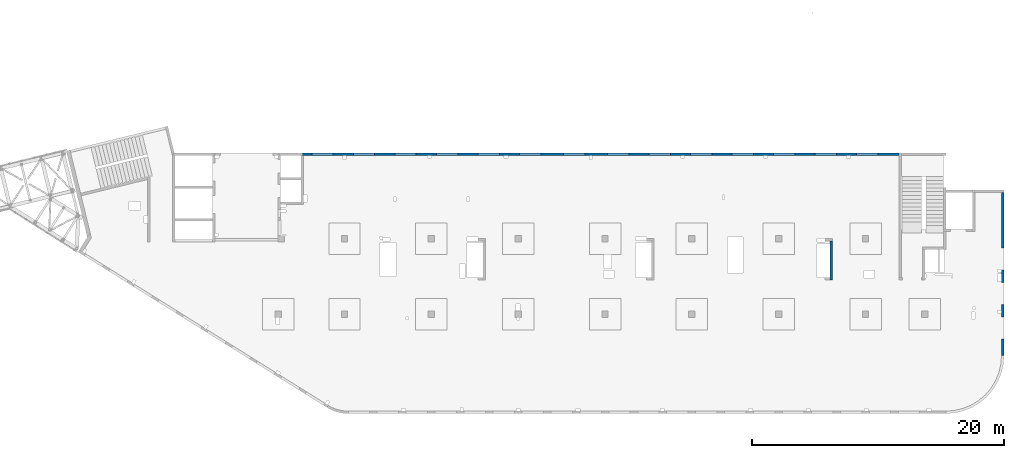
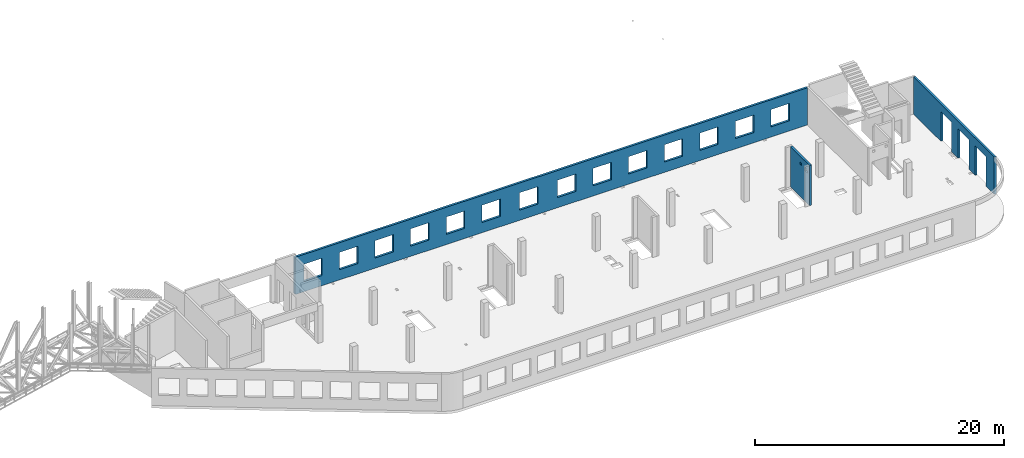
# One storey, part 92 of 93: 3 walls, 19 openings.
"""IFC4 building model written with IfcOpenShell, lengths in millimetres."""

from ifc_helpers import new_model, entity, si_unit, converted_unit, derived_unit, direction, frame, origin, place, context, subcontext, project, spatial, indexed_curve, outline, extrude, polygons, material, type_object, element, save


model = new_model("IFC4")

# Units and contexts
model_context = context("Model", 3, precision=0.01, world=origin(), true_north=direction((6.12303176911189e-17, 1.0)))
plan_context = context("Plan", 3, precision=0.01, world=origin(), true_north=direction((6.12303176911189e-17, 1.0)))
body_context = subcontext(model_context, "Body", "Model", "MODEL_VIEW")
ifc_project = project(units=[si_unit("LENGTHUNIT", "METRE", prefix="MILLI"), si_unit("AREAUNIT", "SQUARE_METRE"), si_unit("VOLUMEUNIT", "CUBIC_METRE"), converted_unit("PLANEANGLEUNIT", "DEGREE", entity("IfcRatioMeasure", 0.0174532925199433), si_unit("PLANEANGLEUNIT", "RADIAN"), dimensions=[0, 0, 0, 0, 0, 0, 0]), si_unit("MASSUNIT", "GRAM", prefix="KILO"), derived_unit("MASSDENSITYUNIT", [(si_unit("MASSUNIT", "GRAM", prefix="KILO"), 1), (si_unit("LENGTHUNIT", "METRE"), -3)]), derived_unit("MOMENTOFINERTIAUNIT", [(si_unit("LENGTHUNIT", "METRE"), 4)]), si_unit("TIMEUNIT", "SECOND"), si_unit("FREQUENCYUNIT", "HERTZ"), si_unit("THERMODYNAMICTEMPERATUREUNIT", "DEGREE_CELSIUS"), derived_unit("THERMALTRANSMITTANCEUNIT", [(si_unit("MASSUNIT", "GRAM", prefix="KILO"), 1), (si_unit("THERMODYNAMICTEMPERATUREUNIT", "KELVIN"), -1), (si_unit("TIMEUNIT", "SECOND"), -3)]), derived_unit("VOLUMETRICFLOWRATEUNIT", [(si_unit("LENGTHUNIT", "METRE"), 3), (si_unit("TIMEUNIT", "SECOND"), -1)]), derived_unit("MASSFLOWRATEUNIT", [(si_unit("MASSUNIT", "GRAM", prefix="KILO"), 1), (si_unit("TIMEUNIT", "SECOND"), -1)]), derived_unit("ROTATIONALFREQUENCYUNIT", [(si_unit("TIMEUNIT", "SECOND"), -1)]), si_unit("ELECTRICCURRENTUNIT", "AMPERE"), si_unit("ELECTRICVOLTAGEUNIT", "VOLT"), si_unit("POWERUNIT", "WATT"), si_unit("FORCEUNIT", "NEWTON", prefix="KILO"), si_unit("ILLUMINANCEUNIT", "LUX"), si_unit("LUMINOUSFLUXUNIT", "LUMEN"), si_unit("LUMINOUSINTENSITYUNIT", "CANDELA"), derived_unit("USERDEFINED", [(si_unit("MASSUNIT", "GRAM", prefix="KILO"), -1), (si_unit("LENGTHUNIT", "METRE"), -2), (si_unit("TIMEUNIT", "SECOND"), 3), (si_unit("LUMINOUSFLUXUNIT", "LUMEN"), 1)]), derived_unit("LINEARVELOCITYUNIT", [(si_unit("LENGTHUNIT", "METRE"), 1), (si_unit("TIMEUNIT", "SECOND"), -1)]), si_unit("PRESSUREUNIT", "PASCAL"), derived_unit("USERDEFINED", [(si_unit("LENGTHUNIT", "METRE"), -2), (si_unit("MASSUNIT", "GRAM", prefix="KILO"), 1), (si_unit("TIMEUNIT", "SECOND"), -2)]), derived_unit("LINEARFORCEUNIT", [(si_unit("MASSUNIT", "GRAM", prefix="KILO"), 1), (si_unit("LENGTHUNIT", "METRE"), 1), (si_unit("TIMEUNIT", "SECOND"), -2), (si_unit("LENGTHUNIT", "METRE"), -1)]), derived_unit("PLANARFORCEUNIT", [(si_unit("MASSUNIT", "GRAM", prefix="KILO"), 1), (si_unit("LENGTHUNIT", "METRE"), 1), (si_unit("TIMEUNIT", "SECOND"), -2), (si_unit("LENGTHUNIT", "METRE"), -2)])], contexts=[model_context, plan_context])

# Site, building, storey
site_placement = place(None, origin())
site = spatial("IfcSite", under=ifc_project, at=site_placement, CompositionType="ELEMENT")
building_placement = place(site_placement, origin())
building = spatial("IfcBuilding", under=site, at=building_placement, CompositionType="ELEMENT")
storey_placement = place(building_placement, frame((0.0, 0.0, 15900.0)))
storey = spatial("IfcBuildingStorey", under=building, at=storey_placement, CompositionType="ELEMENT", Elevation=15900.0)

# Wall, openings
ifc_material = material()
wall_type = type_object("IfcWallType", PredefinedType="STANDARD")
wall_1_placement = place(storey_placement, frame((73469.9994506836, 17369.9992263554, -150.0), z_axis=(0.0, 0.0, 1.0), x_axis=(0.0, -1.0, 0.0)))
wall_1 = element("IfcWall", 1, at=wall_1_placement, inside=storey, type_object=wall_type, material=ifc_material, PredefinedType="NOTDEFINED", context=body_context, shape_type="Tessellation", body=[
    polygons([(12970.0, -99.9999999999918, -2.16573425859679e-12), (12970.0, -99.9999999999918, 3200.0), (12970.0, -99.9999999999918, 3650.0), (9670.00000000001, -99.9999999999876, 3650.0), (9370.00000000001, -99.999999999988, 3650.0), (0.0, -99.9999999999831, 3650.0), (0.0, -99.9999999999831, -2.16573425859679e-12), (4395.00000000004, -99.9999999999946, -2.16573425859679e-12), (4395.00000000004, -100.000000000003, 2900.0), (6145.00000000004, -100.000000000001, 2900.0), (6145.00000000004, -99.9999999999923, -2.16573425859679e-12), (6320.00000000002, -99.999999999992, 0.0), (6485.00000000003, -99.9999999999918, 0.0), (7085.00000000004, -99.999999999991, 0.0), (7145.00000000004, -99.9999999999909, -2.16573425859679e-12), (7145.00000000004, -100.000000000311, 2900.0), (8895.00000000004, -100.000000000309, 2900.0), (8895.00000000004, -99.9999999999886, -2.16573425859679e-12), (9360.00000000002, -99.999999999988, 0.0), (9560.00000000003, -99.9999999999877, 0.0), (9895.00000000005, -99.9999999999959, -2.16573425859679e-12), (9895.00000000005, -99.9999999999959, 2900.0), (11645.0, -99.9999999999936, 2900.0), (11645.0, -99.9999999999936, -2.16573425859679e-12), (12970.0, 100.000000000006, 3650.0), (12970.0, 100.000000000006, 3200.0), (12970.0, 100.000000000006, -2.16573425859679e-12), (11645.0, 100.000000000004, -2.16573425859679e-12), (11645.0, 100.000000000316, 2900.0), (9895.00000000005, 100.000000000314, 2900.0), (9895.00000000004, 100.000000000002, -2.16573425859679e-12), (8895.00000000004, 100.000000000001, -2.16573425859679e-12), (8895.00000000004, 100.000000000001, 2900.0), (7145.00000000004, 99.9999999999983, 2900.0), (7145.00000000004, 99.9999999999983, -2.16573425859679e-12), (6145.00000000004, 99.9999999999969, -2.16573425859679e-12), (6145.00000000004, 100.000000000326, 2900.0), (4395.00000000004, 100.000000000324, 2900.0), (4395.00000000004, 99.9999999999946, -2.16573425859679e-12), (0.0, 100.000000000006, -2.16573425859679e-12), (0.0, 100.000000000006, 3650.0)], [[[1, 2, 3, 4, 5, 6, 7, 8, 9, 10, 11, 12, 13, 14, 15, 16, 17, 18, 19, 20, 21, 22, 23, 24]], [[25, 26, 27, 28, 29, 30, 31, 32, 33, 34, 35, 36, 37, 38, 39, 40, 41]], [[7, 40, 39, 8]], [[3, 2, 1, 27, 26, 25]], [[6, 5, 4, 3, 25, 41]], [[7, 6, 41, 40]], [[22, 30, 29, 23]], [[30, 22, 21, 31]], [[23, 29, 28, 24]], [[33, 17, 16, 34]], [[17, 33, 32, 18]], [[34, 16, 15, 35]], [[9, 38, 37, 10]], [[38, 9, 8, 39]], [[10, 37, 36, 11]], [[35, 15, 14, 13, 12, 11, 36]], [[31, 21, 20, 19, 18, 32]], [[27, 1, 24, 28]]], closed=True),
])
opening_1_placement = place(wall_1_placement, frame((17369.9992263554, -73469.9994506836, 150.0), z_axis=(0.0, 0.0, 1.0), x_axis=(0.0, 1.0, 0.0)))
element("IfcOpeningElement", 2, at=opening_1_placement, cuts=wall_1, PredefinedType="OPENING", context=body_context, shape_type="SweptSolid", body=[
    extrude(outline(indexed_curve([(-1449.99999999999, -874.999999999999), (1450.0, -874.999999999999), (1450.0, 875.0), (-1449.99999999999, 875.0), (-1449.99999999999, -874.999999999999)], self_intersect=False)), frame((73369.9994506836, 6599.9992263554, 1300.0), z_axis=(1.0, 0.0, 0.0), x_axis=(0.0, 0.0, -1.0)), (0.0, 0.0, 1.0), 200.000000000968),
])
opening_2_placement = place(wall_1_placement, frame((17369.9992263554, -73469.9994506836, 150.0), z_axis=(0.0, 0.0, 1.0), x_axis=(0.0, 1.0, 0.0)))
element("IfcOpeningElement", 3, at=opening_2_placement, cuts=wall_1, PredefinedType="OPENING", context=body_context, shape_type="SweptSolid", body=[
    extrude(outline(indexed_curve([(-874.999999999999, -1449.99999999999), (874.999999999999, -1449.99999999999), (874.999999999999, 1450.0), (-874.999999999999, 1450.0), (-874.999999999999, -1449.99999999999)], self_intersect=False)), frame((73369.9994506826, 9349.99922635541, 1300.0), z_axis=(1.0, 0.0, 0.0), x_axis=(0.0, -1.0, 0.0)), (0.0, 0.0, 1.0), 200.000000000968),
])
opening_3_placement = place(wall_1_placement, frame((17369.9992263554, -73469.9994506836, 150.0), z_axis=(0.0, 0.0, 1.0), x_axis=(0.0, 1.0, 0.0)))
element("IfcOpeningElement", 4, at=opening_3_placement, cuts=wall_1, PredefinedType="OPENING", context=body_context, shape_type="SweptSolid", body=[
    extrude(outline(indexed_curve([(-1449.99999999999, -875.0), (1450.0, -875.0), (1450.0, 875.0), (-1449.99999999999, 875.0), (-1449.99999999999, -875.0)], self_intersect=False)), frame((73369.9994506836, 12099.9992263554, 1300.0), z_axis=(1.0, 0.0, 0.0), x_axis=(0.0, 0.0, -1.0)), (0.0, 0.0, 1.0), 200.000000000968),
])

wall_2_placement = place(storey_placement, frame((65230.0002685547, 20399.9998657227, -150.0), z_axis=(0.0, 0.0, 1.0), x_axis=(-1.0, 0.0, 0.0)))
wall_2 = element("IfcWall", 5, at=wall_2_placement, inside=storey, type_object=wall_type, material=ifc_material, PredefinedType="NOTDEFINED", context=body_context, shape_type="Tessellation", body=[
    polygons([(8.66293703438714e-12, -99.9999999999989, -2.16573425859679e-12), (47405.0, -99.9999999999989, -2.16573425859679e-12), (47405.0, -99.9999999999989, 49.9999999999995), (47505.0, -99.9999999999989, 49.9999999999995), (47505.0, -99.9999999999989, 3650.0), (8.66293703438714e-12, -99.9999999999989, 3650.0), (28460.0, -100.000000000319, 2700.0), (30160.0, -100.000000000319, 2700.0), (30160.0, -100.000000000319, 1000.00000000001), (28460.0, -100.000000000319, 1000.00000000001), (1660.00000000009, -100.000000000319, 2700.0), (3360.00000000009, -100.000000000319, 2700.0), (3360.00000000009, -100.000000000319, 1000.00000000001), (1660.00000000009, -100.000000000319, 1000.00000000001), (4960.00000000009, -100.000000000319, 2700.0), (6660.00000000009, -100.000000000319, 2700.0), (6660.00000000009, -100.000000000319, 1000.00000000001), (4960.00000000009, -100.000000000319, 1000.00000000001), (8260.00000000008, -100.000000000319, 2700.0), (9960.00000000008, -100.000000000319, 2700.0), (9960.00000000008, -100.000000000319, 1000.00000000001), (8260.00000000008, -100.000000000319, 1000.00000000001), (11560.0000000001, -100.000000000319, 2700.0), (13260.0000000001, -100.000000000319, 2700.0), (13260.0000000001, -100.000000000319, 1000.00000000001), (11560.0000000001, -100.000000000319, 1000.00000000001), (14860.0000000001, -100.000000000319, 2700.0), (16560.0000000001, -100.000000000319, 2700.0), (16560.0000000001, -100.000000000319, 1000.00000000001), (14860.0000000001, -100.000000000319, 1000.00000000001), (18160.0000000001, -100.000000000319, 2700.0), (19860.0000000001, -100.000000000319, 2700.0), (19860.0000000001, -100.000000000319, 1000.00000000001), (18160.0000000001, -100.000000000319, 1000.00000000001), (21460.0000000001, -100.000000000319, 2700.0), (23160.0000000001, -100.000000000319, 2700.0), (23160.0000000001, -100.000000000319, 1000.00000000001), (21460.0000000001, -100.000000000319, 1000.00000000001), (24960.0000000001, -100.000000000319, 2700.0), (26660.0000000001, -100.000000000319, 2700.0), (26660.0000000001, -100.000000000319, 1000.00000000001), (24960.0000000001, -100.000000000319, 1000.00000000001), (31760.0000000001, -100.000000000319, 2700.0), (33460.0000000001, -100.000000000319, 2700.0), (33460.0000000001, -100.000000000319, 1000.00000000001), (31760.0000000001, -100.000000000319, 1000.00000000001), (35060.0000000001, -100.000000000319, 2700.0), (36760.0000000001, -100.000000000319, 2700.0), (36760.0000000001, -100.000000000319, 1000.00000000001), (35060.0000000001, -100.000000000319, 1000.00000000001), (38360.0000000001, -100.000000000319, 2700.0), (40060.0000000001, -100.000000000319, 2700.0), (40060.0000000001, -100.000000000319, 1000.00000000001), (38360.0000000001, -100.000000000319, 1000.00000000001), (41660.0, -100.000000000319, 2700.0), (43360.0, -100.000000000319, 2700.0), (43360.0, -100.000000000319, 1000.00000000001), (41660.0, -100.000000000319, 1000.00000000001), (44960.0, -100.000000000319, 2700.0), (46660.0, -100.000000000319, 2700.0), (46660.0, -100.000000000319, 1000.00000000001), (44960.0, -100.000000000319, 1000.00000000001), (30160.0, 99.9999999999989, 2700.0), (28460.0, 99.9999999999989, 2700.0), (28460.0, 99.9999999999989, 1000.00000000001), (30160.0, 99.9999999999989, 1000.00000000001), (3360.00000000009, 99.9999999999989, 2700.0), (1660.00000000009, 99.9999999999989, 2700.0), (1660.00000000009, 99.9999999999989, 1000.00000000001), (3360.00000000009, 99.9999999999989, 1000.00000000001), (6660.00000000009, 99.9999999999989, 2700.0), (4960.00000000009, 99.9999999999989, 2700.0), (4960.00000000009, 99.9999999999989, 1000.00000000001), (6660.00000000009, 99.9999999999989, 1000.00000000001), (9960.00000000008, 99.9999999999989, 2700.0), (8260.00000000008, 99.9999999999989, 2700.0), (8260.00000000008, 99.9999999999989, 1000.00000000001), (9960.00000000008, 99.9999999999989, 1000.00000000001), (13260.0000000001, 99.9999999999989, 2700.0), (11560.0000000001, 99.9999999999989, 2700.0), (11560.0000000001, 99.9999999999989, 1000.00000000001), (13260.0000000001, 99.9999999999989, 1000.00000000001), (16560.0000000001, 99.9999999999989, 2700.0), (14860.0000000001, 99.9999999999989, 2700.0), (14860.0000000001, 99.9999999999989, 1000.00000000001), (16560.0000000001, 99.9999999999989, 1000.00000000001), (19860.0000000001, 99.9999999999989, 2700.0), (18160.0000000001, 99.9999999999989, 2700.0), (18160.0000000001, 99.9999999999989, 1000.00000000001), (19860.0000000001, 99.9999999999989, 1000.00000000001), (23160.0000000001, 99.9999999999989, 2700.0), (21460.0000000001, 99.9999999999989, 2700.0), (21460.0000000001, 99.9999999999989, 1000.00000000001), (23160.0000000001, 99.9999999999989, 1000.00000000001), (26660.0000000001, 99.9999999999989, 2700.0), (24960.0000000001, 99.9999999999989, 2700.0), (24960.0000000001, 99.9999999999989, 1000.00000000001), (26660.0000000001, 99.9999999999989, 1000.00000000001), (33460.0000000001, 99.9999999999989, 2700.0), (31760.0000000001, 99.9999999999989, 2700.0), (31760.0000000001, 99.9999999999989, 1000.00000000001), (33460.0000000001, 99.9999999999989, 1000.00000000001), (36760.0000000001, 99.9999999999989, 2700.0), (35060.0000000001, 99.9999999999989, 2700.0), (35060.0000000001, 99.9999999999989, 1000.00000000001), (36760.0000000001, 99.9999999999989, 1000.00000000001), (40060.0000000001, 99.9999999999989, 2700.0), (38360.0000000001, 99.9999999999989, 2700.0), (38360.0000000001, 99.9999999999989, 1000.00000000001), (40060.0000000001, 99.9999999999989, 1000.00000000001), (43360.0, 99.9999999999989, 2700.0), (41660.0, 99.9999999999989, 2700.0), (41660.0, 99.9999999999989, 1000.00000000001), (43360.0, 99.9999999999989, 1000.00000000001), (46660.0, 99.9999999999989, 2700.0), (44960.0, 99.9999999999989, 2700.0), (44960.0, 99.9999999999989, 1000.00000000001), (46660.0, 99.9999999999989, 1000.00000000001), (8.66293703438714e-12, 99.9999999999989, -2.16573425859679e-12), (8.66293703438714e-12, 99.9999999999989, 3650.0), (47305.0, 99.9999999999989, 3650.0), (47505.0, 99.9999999999989, 3650.0), (47505.0, 99.9999999999989, 49.9999999999995), (47405.0, 99.9999999999989, 49.9999999999995), (47405.0, 99.9999999999989, -2.16573425859679e-12), (47305.0, 99.9999999999989, 0.0)], [[[1, 2, 3, 4, 5, 6], [7, 8, 9, 10], [11, 12, 13, 14], [15, 16, 17, 18], [19, 20, 21, 22], [23, 24, 25, 26], [27, 28, 29, 30], [31, 32, 33, 34], [35, 36, 37, 38], [39, 40, 41, 42], [43, 44, 45, 46], [47, 48, 49, 50], [51, 52, 53, 54], [55, 56, 57, 58], [59, 60, 61, 62]], [[119, 120, 121, 122, 123, 124, 125, 126], [63, 64, 65, 66], [67, 68, 69, 70], [71, 72, 73, 74], [75, 76, 77, 78], [79, 80, 81, 82], [83, 84, 85, 86], [87, 88, 89, 90], [91, 92, 93, 94], [95, 96, 97, 98], [99, 100, 101, 102], [103, 104, 105, 106], [107, 108, 109, 110], [111, 112, 113, 114], [115, 116, 117, 118]], [[2, 1, 119, 126, 125]], [[6, 5, 122, 121, 120]], [[8, 7, 64, 63]], [[8, 63, 66, 9]], [[9, 66, 65, 10]], [[64, 7, 10, 65]], [[12, 11, 68, 67]], [[12, 67, 70, 13]], [[13, 70, 69, 14]], [[68, 11, 14, 69]], [[16, 15, 72, 71]], [[16, 71, 74, 17]], [[17, 74, 73, 18]], [[72, 15, 18, 73]], [[20, 19, 76, 75]], [[20, 75, 78, 21]], [[21, 78, 77, 22]], [[76, 19, 22, 77]], [[24, 23, 80, 79]], [[24, 79, 82, 25]], [[25, 82, 81, 26]], [[80, 23, 26, 81]], [[28, 27, 84, 83]], [[28, 83, 86, 29]], [[29, 86, 85, 30]], [[84, 27, 30, 85]], [[32, 31, 88, 87]], [[32, 87, 90, 33]], [[33, 90, 89, 34]], [[88, 31, 34, 89]], [[36, 35, 92, 91]], [[36, 91, 94, 37]], [[37, 94, 93, 38]], [[92, 35, 38, 93]], [[40, 39, 96, 95]], [[40, 95, 98, 41]], [[41, 98, 97, 42]], [[96, 39, 42, 97]], [[44, 43, 100, 99]], [[44, 99, 102, 45]], [[45, 102, 101, 46]], [[100, 43, 46, 101]], [[48, 47, 104, 103]], [[48, 103, 106, 49]], [[49, 106, 105, 50]], [[104, 47, 50, 105]], [[52, 51, 108, 107]], [[52, 107, 110, 53]], [[53, 110, 109, 54]], [[108, 51, 54, 109]], [[56, 55, 112, 111]], [[56, 111, 114, 57]], [[57, 114, 113, 58]], [[112, 55, 58, 113]], [[60, 59, 116, 115]], [[60, 115, 118, 61]], [[61, 118, 117, 62]], [[116, 59, 62, 117]], [[3, 2, 125, 124]], [[5, 4, 123, 122]], [[1, 6, 120, 119]], [[123, 4, 3, 124]]], closed=True),
])
opening_4_placement = place(wall_2_placement, frame((65230.0002685547, 20399.9998657227, 150.0), z_axis=(0.0, 0.0, 1.0), x_axis=(-1.0, 0.0, 0.0)))
element("IfcOpeningElement", 6, at=opening_4_placement, cuts=wall_2, PredefinedType="OPENING", context=body_context, shape_type="SweptSolid", body=[
    extrude(outline(indexed_curve([(-850.000000000002, -849.999999999993), (850.0, -849.999999999993), (850.0, 849.999999999995), (-850.000000000002, 849.999999999995), (-850.000000000002, -849.999999999993)], self_intersect=False)), frame((19420.0002685547, 20499.9998657236, 1700.0), z_axis=(0.0, -1.0, 0.0), x_axis=(-1.0, 0.0, 0.0)), (0.0, 0.0, 1.0), 200.000000000959),
])
opening_5_placement = place(wall_2_placement, frame((65230.0002685547, 20399.9998657227, 150.0), z_axis=(0.0, 0.0, 1.0), x_axis=(-1.0, 0.0, 0.0)))
element("IfcOpeningElement", 7, at=opening_5_placement, cuts=wall_2, PredefinedType="OPENING", context=body_context, shape_type="SweptSolid", body=[
    extrude(outline(indexed_curve([(-850.000000000002, -849.999999999993), (849.999999999997, -849.999999999993), (849.999999999997, 849.999999999995), (-850.000000000002, 849.999999999995), (-850.000000000002, -849.999999999993)], self_intersect=False)), frame((22720.0002685547, 20499.9998657236, 1700.0), z_axis=(0.0, -1.0, 0.0), x_axis=(-1.0, 0.0, 0.0)), (0.0, 0.0, 1.0), 200.000000000959),
])
opening_6_placement = place(wall_2_placement, frame((65230.0002685547, 20399.9998657227, 150.0), z_axis=(0.0, 0.0, 1.0), x_axis=(-1.0, 0.0, 0.0)))
element("IfcOpeningElement", 8, at=opening_6_placement, cuts=wall_2, PredefinedType="OPENING", context=body_context, shape_type="SweptSolid", body=[
    extrude(outline(indexed_curve([(-850.000000000002, -849.999999999993), (849.999999999997, -849.999999999993), (849.999999999997, 849.999999999995), (-850.000000000002, 849.999999999995), (-850.000000000002, -849.999999999993)], self_intersect=False)), frame((26020.0002685547, 20499.9998657236, 1700.0), z_axis=(0.0, -1.0, 0.0), x_axis=(-1.0, 0.0, 0.0)), (0.0, 0.0, 1.0), 200.000000000959),
])
opening_7_placement = place(wall_2_placement, frame((65230.0002685547, 20399.9998657227, 150.0), z_axis=(0.0, 0.0, 1.0), x_axis=(-1.0, 0.0, 0.0)))
element("IfcOpeningElement", 9, at=opening_7_placement, cuts=wall_2, PredefinedType="OPENING", context=body_context, shape_type="SweptSolid", body=[
    extrude(outline(indexed_curve([(-850.000000000002, -849.999999999993), (849.999999999997, -849.999999999993), (849.999999999997, 849.999999999995), (-850.000000000002, 849.999999999995), (-850.000000000002, -849.999999999993)], self_intersect=False)), frame((29320.0002685547, 20499.9998657236, 1700.0), z_axis=(0.0, -1.0, 0.0), x_axis=(-1.0, 0.0, 0.0)), (0.0, 0.0, 1.0), 200.000000000959),
])
opening_8_placement = place(wall_2_placement, frame((65230.0002685547, 20399.9998657227, 150.0), z_axis=(0.0, 0.0, 1.0), x_axis=(-1.0, 0.0, 0.0)))
element("IfcOpeningElement", 10, at=opening_8_placement, cuts=wall_2, PredefinedType="OPENING", context=body_context, shape_type="SweptSolid", body=[
    extrude(outline(indexed_curve([(-849.999999999997, -849.999999999993), (850.000000000002, -849.999999999993), (850.000000000002, 849.999999999995), (-849.999999999997, 849.999999999995), (-849.999999999997, -849.999999999993)], self_intersect=False)), frame((32620.0002685547, 20499.9998657236, 1700.0), z_axis=(0.0, -1.0, 0.0), x_axis=(-1.0, 0.0, 0.0)), (0.0, 0.0, 1.0), 200.000000000959),
])
opening_9_placement = place(wall_2_placement, frame((65230.0002685547, 20399.9998657227, 150.0), z_axis=(0.0, 0.0, 1.0), x_axis=(-1.0, 0.0, 0.0)))
element("IfcOpeningElement", 11, at=opening_9_placement, cuts=wall_2, PredefinedType="OPENING", context=body_context, shape_type="SweptSolid", body=[
    extrude(outline(indexed_curve([(-849.999999999997, -849.999999999993), (850.000000000006, -849.999999999993), (850.000000000006, 849.999999999995), (-849.999999999997, 849.999999999995), (-849.999999999997, -849.999999999993)], self_intersect=False)), frame((39420.0002685547, 20499.9998657236, 1700.0), z_axis=(0.0, -1.0, 0.0), x_axis=(-1.0, 0.0, 0.0)), (0.0, 0.0, 1.0), 200.000000000959),
])
opening_10_placement = place(wall_2_placement, frame((65230.0002685547, 20399.9998657227, 150.0), z_axis=(0.0, 0.0, 1.0), x_axis=(-1.0, 0.0, 0.0)))
element("IfcOpeningElement", 12, at=opening_10_placement, cuts=wall_2, PredefinedType="OPENING", context=body_context, shape_type="SweptSolid", body=[
    extrude(outline(indexed_curve([(-850.000000000006, -849.999999999993), (849.999999999997, -849.999999999993), (849.999999999997, 849.999999999995), (-850.000000000006, 849.999999999995), (-850.000000000006, -849.999999999993)], self_intersect=False)), frame((42920.0002685547, 20499.9998657236, 1700.0), z_axis=(0.0, -1.0, 0.0), x_axis=(-1.0, 0.0, 0.0)), (0.0, 0.0, 1.0), 200.000000000959),
])
opening_11_placement = place(wall_2_placement, frame((65230.0002685547, 20399.9998657227, 150.0), z_axis=(0.0, 0.0, 1.0), x_axis=(-1.0, 0.0, 0.0)))
element("IfcOpeningElement", 13, at=opening_11_placement, cuts=wall_2, PredefinedType="OPENING", context=body_context, shape_type="SweptSolid", body=[
    extrude(outline(indexed_curve([(-849.999999999997, -849.999999999993), (850.000000000006, -849.999999999993), (850.000000000006, 849.999999999995), (-849.999999999997, 849.999999999995), (-849.999999999997, -849.999999999993)], self_intersect=False)), frame((46220.0002685547, 20499.9998657236, 1700.0), z_axis=(0.0, -1.0, 0.0), x_axis=(-1.0, 0.0, 0.0)), (0.0, 0.0, 1.0), 200.000000000959),
])
opening_12_placement = place(wall_2_placement, frame((65230.0002685547, 20399.9998657227, 150.0), z_axis=(0.0, 0.0, 1.0), x_axis=(-1.0, 0.0, 0.0)))
element("IfcOpeningElement", 14, at=opening_12_placement, cuts=wall_2, PredefinedType="OPENING", context=body_context, shape_type="SweptSolid", body=[
    extrude(outline(indexed_curve([(-849.999999999997, -849.999999999993), (850.000000000006, -849.999999999993), (850.000000000006, 849.999999999995), (-849.999999999997, 849.999999999995), (-849.999999999997, -849.999999999993)], self_intersect=False)), frame((49520.0002685547, 20499.9998657236, 1700.0), z_axis=(0.0, -1.0, 0.0), x_axis=(-1.0, 0.0, 0.0)), (0.0, 0.0, 1.0), 200.000000000959),
])
opening_13_placement = place(wall_2_placement, frame((65230.0002685547, 20399.9998657227, 150.0), z_axis=(0.0, 0.0, 1.0), x_axis=(-1.0, 0.0, 0.0)))
element("IfcOpeningElement", 15, at=opening_13_placement, cuts=wall_2, PredefinedType="OPENING", context=body_context, shape_type="SweptSolid", body=[
    extrude(outline(indexed_curve([(-849.999999999997, -849.999999999993), (850.000000000006, -849.999999999993), (850.000000000006, 849.999999999995), (-849.999999999997, 849.999999999995), (-849.999999999997, -849.999999999993)], self_intersect=False)), frame((52820.0002685547, 20499.9998657236, 1700.0), z_axis=(0.0, -1.0, 0.0), x_axis=(-1.0, 0.0, 0.0)), (0.0, 0.0, 1.0), 200.000000000959),
])
opening_14_placement = place(wall_2_placement, frame((65230.0002685547, 20399.9998657227, 150.0), z_axis=(0.0, 0.0, 1.0), x_axis=(-1.0, 0.0, 0.0)))
element("IfcOpeningElement", 16, at=opening_14_placement, cuts=wall_2, PredefinedType="OPENING", context=body_context, shape_type="SweptSolid", body=[
    extrude(outline(indexed_curve([(-849.999999999997, -849.999999999993), (850.000000000006, -849.999999999993), (850.000000000006, 849.999999999995), (-849.999999999997, 849.999999999995), (-849.999999999997, -849.999999999993)], self_intersect=False)), frame((56120.0002685547, 20499.9998657236, 1700.0), z_axis=(0.0, -1.0, 0.0), x_axis=(-1.0, 0.0, 0.0)), (0.0, 0.0, 1.0), 200.000000000959),
])
opening_15_placement = place(wall_2_placement, frame((65230.0002685547, 20399.9998657227, 150.0), z_axis=(0.0, 0.0, 1.0), x_axis=(-1.0, 0.0, 0.0)))
element("IfcOpeningElement", 17, at=opening_15_placement, cuts=wall_2, PredefinedType="OPENING", context=body_context, shape_type="SweptSolid", body=[
    extrude(outline(indexed_curve([(-849.999999999997, -849.999999999993), (850.000000000006, -849.999999999993), (850.000000000006, 849.999999999995), (-849.999999999997, 849.999999999995), (-849.999999999997, -849.999999999993)], self_intersect=False)), frame((59420.0002685547, 20499.9998657236, 1700.0), z_axis=(0.0, -1.0, 0.0), x_axis=(-1.0, 0.0, 0.0)), (0.0, 0.0, 1.0), 200.000000000959),
])
opening_16_placement = place(wall_2_placement, frame((65230.0002685547, 20399.9998657227, 150.0), z_axis=(0.0, 0.0, 1.0), x_axis=(-1.0, 0.0, 0.0)))
element("IfcOpeningElement", 18, at=opening_16_placement, cuts=wall_2, PredefinedType="OPENING", context=body_context, shape_type="SweptSolid", body=[
    extrude(outline(indexed_curve([(-849.999999999997, -849.999999999993), (850.000000000006, -849.999999999993), (850.000000000006, 849.999999999995), (-849.999999999997, 849.999999999995), (-849.999999999997, -849.999999999993)], self_intersect=False)), frame((62720.0002685547, 20499.9998657236, 1700.0), z_axis=(0.0, -1.0, 0.0), x_axis=(-1.0, 0.0, 0.0)), (0.0, 0.0, 1.0), 200.000000000959),
])
opening_17_placement = place(wall_2_placement, frame((65230.0002685547, 20399.9998657227, 150.0), z_axis=(0.0, 0.0, 1.0), x_axis=(-1.0, 0.0, 0.0)))
element("IfcOpeningElement", 19, at=opening_17_placement, cuts=wall_2, PredefinedType="OPENING", context=body_context, shape_type="SweptSolid", body=[
    extrude(outline(indexed_curve([(-849.999999999997, -849.999999999993), (850.000000000002, -849.999999999993), (850.000000000002, 849.999999999995), (-849.999999999997, 849.999999999995), (-849.999999999997, -849.999999999993)], self_intersect=False)), frame((35920.0002685547, 20499.9998657236, 1700.0), z_axis=(0.0, -1.0, 0.0), x_axis=(-1.0, 0.0, 0.0)), (0.0, 0.0, 1.0), 200.000000000959),
])

wall_3_placement = place(storey_placement, frame((59830.0002685547, 13499.9992263555, -150.0), z_axis=(0.0, 0.0, 1.0), x_axis=(0.0, -1.0, 0.0)))
wall_3 = element("IfcWall", 20, at=wall_3_placement, inside=storey, type_object=wall_type, material=ifc_material, PredefinedType="NOTDEFINED", context=body_context, shape_type="Tessellation", body=[
    polygons([(-2.16573425859679e-12, -99.999999999987, -2.16573425859679e-12), (2875.00000000001, -99.9999999999967, 0.0), (3075.00000000001, -99.9999999999962, -2.16573425859679e-12), (3075.00000000001, -99.9999999999962, 3950.0), (2875.00000000001, -99.9999999999967, 3950.0), (-2.16573425859679e-12, -99.999999999987, 3950.0), (1560.00000000001, -100.000000000009, 3400.0), (1810.00000000001, -100.000000000008, 3400.0), (1810.00000000001, -100.000000000008, 3150.00000000001), (1560.00000000001, -100.000000000009, 3150.00000000001), (2360.00000000001, -100.000000000007, 3330.0), (2710.00000000001, -100.000000000006, 3330.0), (2710.00000000001, -100.000000000006, 2980.00000000001), (2360.00000000001, -100.000000000007, 2980.00000000001), (-2.16573425859679e-12, 100.000000000002, -2.16573425859679e-12), (-2.16573425859679e-12, 100.000000000002, 3950.0), (3075.00000000001, 99.999999999993, 3950.0), (3075.00000000001, 99.999999999993, -2.16573425859679e-12), (1810.00000000001, 100.000000000319, 3400.0), (1560.00000000001, 100.000000000318, 3400.0), (1560.00000000001, 100.000000000318, 3150.00000000001), (1810.00000000001, 100.000000000319, 3150.00000000001), (2710.00000000001, 100.000000000321, 3330.0), (2360.00000000001, 100.00000000032, 3330.0), (2360.00000000001, 100.00000000032, 2980.00000000001), (2710.00000000001, 100.000000000321, 2980.00000000001)], [[[1, 2, 3, 4, 5, 6], [7, 8, 9, 10], [11, 12, 13, 14]], [[15, 16, 17, 18], [19, 20, 21, 22], [23, 24, 25, 26]], [[3, 2, 1, 15, 18]], [[6, 5, 4, 17, 16]], [[1, 6, 16, 15]], [[4, 3, 18, 17]], [[20, 19, 8, 7]], [[20, 7, 10, 21]], [[21, 10, 9, 22]], [[8, 19, 22, 9]], [[24, 23, 12, 11]], [[24, 11, 14, 25]], [[25, 14, 13, 26]], [[12, 23, 26, 13]]], closed=True),
])
opening_18_placement = place(wall_3_placement, frame((13499.9992263555, -59830.0002685547, 150.0), z_axis=(0.0, 0.0, 1.0), x_axis=(0.0, 1.0, 0.0)))
element("IfcOpeningElement", 21, at=opening_18_placement, cuts=wall_3, PredefinedType="OPENING", context=body_context, shape_type="SweptSolid", body=[
    extrude(outline(indexed_curve([(-174.999999999995, -174.999999999999), (174.999999999991, -174.999999999999), (174.999999999991, 175.000000000001), (-174.999999999995, 175.000000000001), (-174.999999999995, -174.999999999999)], self_intersect=False)), frame((59730.0002685547, 10964.9992263555, 3005.0), z_axis=(1.0, 0.0, 0.0), x_axis=(0.0, 0.0, -1.0)), (0.0, 0.0, 1.0), 200.000000000968),
])
opening_19_placement = place(wall_3_placement, frame((13499.9992263555, -59830.0002685547, 150.0), z_axis=(0.0, 0.0, 1.0), x_axis=(0.0, 1.0, 0.0)))
element("IfcOpeningElement", 22, at=opening_19_placement, cuts=wall_3, PredefinedType="OPENING", context=body_context, shape_type="SweptSolid", body=[
    extrude(outline(indexed_curve([(-124.999999999991, -125.0), (124.999999999993, -125.0), (124.999999999993, 125.0), (-124.999999999991, 125.0), (-124.999999999991, -125.0)], self_intersect=False)), frame((59730.0002685547, 11814.9992263555, 3125.0), z_axis=(1.0, 0.0, 0.0), x_axis=(0.0, 0.0, -1.0)), (0.0, 0.0, 1.0), 200.000000000968),
])

save(model, "model.ifc")
